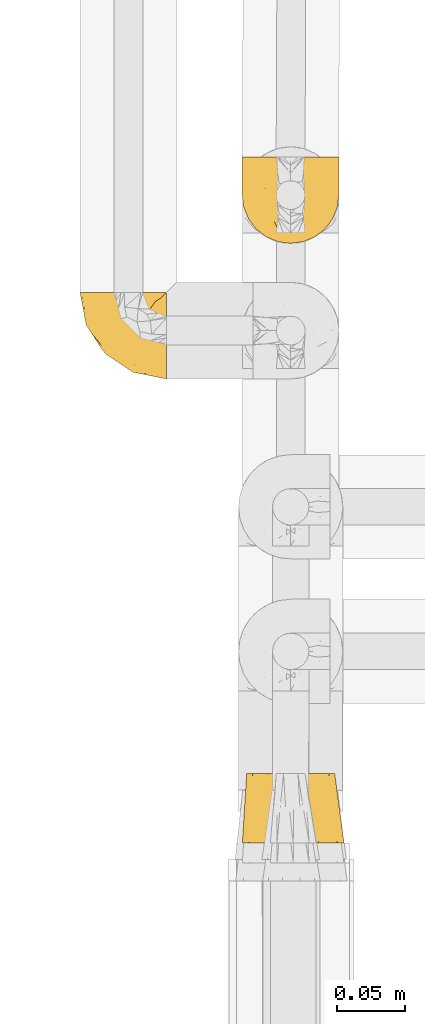
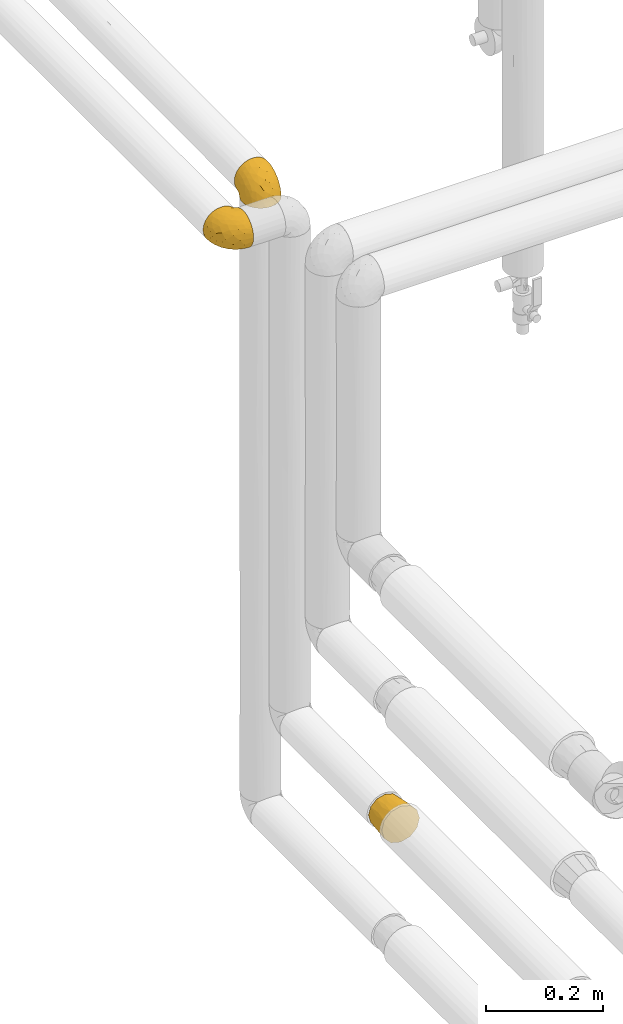
# One storey, part 80 of 827: 3 coverings.
"""IFC2X3 building model written with IfcOpenShell, lengths in millimetres."""

from ifc_helpers import new_model, entity, si_unit, converted_unit, derived_unit, direction, frame, origin, place, context, subcontext, project, spatial, faceted_brep, element, save


model = new_model("IFC2X3")

# Units and contexts
model_context = context("Model", 3, precision=0.01, world=origin(), true_north=direction((6.12303176911189e-17, 1.0)))
body_context = subcontext(model_context, "Body", "Model", "MODEL_VIEW")
ifc_project = project(units=[si_unit("LENGTHUNIT", "METRE", prefix="MILLI"), si_unit("AREAUNIT", "SQUARE_METRE"), si_unit("VOLUMEUNIT", "CUBIC_METRE"), converted_unit("PLANEANGLEUNIT", "DEGREE", entity("IfcRatioMeasure", 0.0174532925199433), si_unit("PLANEANGLEUNIT", "RADIAN"), dimensions=[0, 0, 0, 0, 0, 0, 0]), si_unit("MASSUNIT", "GRAM", prefix="KILO"), derived_unit("MASSDENSITYUNIT", [(si_unit("MASSUNIT", "GRAM", prefix="KILO"), 1), (si_unit("LENGTHUNIT", "METRE"), -3)]), derived_unit("MOMENTOFINERTIAUNIT", [(si_unit("LENGTHUNIT", "METRE"), 4)]), si_unit("TIMEUNIT", "SECOND"), si_unit("FREQUENCYUNIT", "HERTZ"), si_unit("THERMODYNAMICTEMPERATUREUNIT", "DEGREE_CELSIUS"), derived_unit("THERMALTRANSMITTANCEUNIT", [(si_unit("MASSUNIT", "GRAM", prefix="KILO"), 1), (si_unit("THERMODYNAMICTEMPERATUREUNIT", "KELVIN"), -1), (si_unit("TIMEUNIT", "SECOND"), -3)]), derived_unit("VOLUMETRICFLOWRATEUNIT", [(si_unit("LENGTHUNIT", "METRE"), 3), (si_unit("TIMEUNIT", "SECOND"), -1)]), derived_unit("MASSFLOWRATEUNIT", [(si_unit("MASSUNIT", "GRAM", prefix="KILO"), 1), (si_unit("TIMEUNIT", "SECOND"), -1)]), derived_unit("ROTATIONALFREQUENCYUNIT", [(si_unit("TIMEUNIT", "SECOND"), -1)]), si_unit("ELECTRICCURRENTUNIT", "AMPERE"), si_unit("ELECTRICVOLTAGEUNIT", "VOLT"), si_unit("POWERUNIT", "WATT"), si_unit("FORCEUNIT", "NEWTON", prefix="KILO"), si_unit("ILLUMINANCEUNIT", "LUX"), si_unit("LUMINOUSFLUXUNIT", "LUMEN"), si_unit("LUMINOUSINTENSITYUNIT", "CANDELA"), derived_unit("USERDEFINED", [(si_unit("MASSUNIT", "GRAM", prefix="KILO"), -1), (si_unit("LENGTHUNIT", "METRE"), -2), (si_unit("TIMEUNIT", "SECOND"), 3), (si_unit("LUMINOUSFLUXUNIT", "LUMEN"), 1)]), derived_unit("LINEARVELOCITYUNIT", [(si_unit("LENGTHUNIT", "METRE"), 1), (si_unit("TIMEUNIT", "SECOND"), -1)]), si_unit("PRESSUREUNIT", "PASCAL"), derived_unit("USERDEFINED", [(si_unit("LENGTHUNIT", "METRE"), -2), (si_unit("MASSUNIT", "GRAM", prefix="KILO"), 1), (si_unit("TIMEUNIT", "SECOND"), -2)]), derived_unit("LINEARFORCEUNIT", [(si_unit("MASSUNIT", "GRAM", prefix="KILO"), 1), (si_unit("LENGTHUNIT", "METRE"), 1), (si_unit("TIMEUNIT", "SECOND"), -2), (si_unit("LENGTHUNIT", "METRE"), -1)]), derived_unit("PLANARFORCEUNIT", [(si_unit("MASSUNIT", "GRAM", prefix="KILO"), 1), (si_unit("LENGTHUNIT", "METRE"), 1), (si_unit("TIMEUNIT", "SECOND"), -2), (si_unit("LENGTHUNIT", "METRE"), -2)])], contexts=[model_context])

# Site, building, storey
site_placement = place(None, origin())
site = spatial("IfcSite", under=ifc_project, at=site_placement, CompositionType="ELEMENT")
building_placement = place(site_placement, origin())
building = spatial("IfcBuilding", under=site, at=building_placement, CompositionType="ELEMENT")
storey_placement = place(building_placement, frame((0.0, 0.0, 28200.0)))
storey = spatial("IfcBuildingStorey", under=building, at=storey_placement, Name="08", CompositionType="ELEMENT", Elevation=28200.0)

# Coverings
covering_1_placement = place(storey_placement, frame((17769.65, 11958.96, 1862.75)))
element("IfcCovering", 1, at=covering_1_placement, inside=storey, Name=":ADSK_", ObjectType=":ADSK_", PredefinedType="INSULATION", context=body_context, shape_type="Brep", body=[
    faceted_brep([(65.25, 21.77, 69.36), (65.25, 15.01, 65.11), (65.25, 9.37, 59.47), (65.25, 5.12, 52.71), (65.25, 2.49, 45.17), (65.25, 1.6, 37.25), (65.25, 2.49, 29.31), (65.25, 5.13, 21.77), (65.25, 9.38, 15.01), (65.25, 15.02, 9.37), (65.25, 21.78, 5.12), (65.25, 29.32, 2.49), (65.25, 37.25, 1.6), (65.25, 45.15, 2.48), (65.25, 52.65, 5.1), (65.25, 59.39, 9.31), (65.25, 65.02, 14.9), (65.25, 65.02, 16.96), (65.25, 65.02, 18.43), (65.25, 65.02, 20.19), (65.25, 65.02, 21.96), (65.25, 65.02, 23.72), (65.25, 65.02, 25.49), (65.25, 65.02, 27.25), (65.25, 65.02, 29.02), (65.25, 65.02, 30.78), (65.25, 65.02, 32.55), (65.25, 65.02, 34.31), (65.25, 65.02, 36.08), (65.25, 65.02, 37.84), (65.25, 65.02, 39.61), (65.25, 65.02, 41.37), (65.25, 65.02, 43.14), (65.25, 65.02, 45.19), (65.25, 65.02, 47.25), (65.25, 65.02, 49.31), (65.25, 65.02, 51.36), (65.25, 65.02, 53.42), (65.25, 65.02, 55.48), (65.25, 65.02, 57.53), (65.25, 65.02, 59.59), (65.25, 59.38, 65.19), (65.25, 52.64, 69.4), (65.25, 45.13, 72.01), (65.25, 37.25, 72.9), (65.25, 29.31, 72.0), (65.02, 65.25, 14.9), (59.38, 65.25, 9.3), (52.65, 65.25, 5.09), (45.14, 65.25, 2.48), (37.25, 65.25, 1.6), (28.02, 65.25, 2.81), (19.42, 65.25, 6.37), (12.04, 65.25, 12.04), (6.37, 65.25, 19.42), (2.81, 65.25, 28.02), (1.6, 65.25, 37.25), (2.81, 65.25, 46.47), (6.37, 65.25, 55.07), (12.04, 65.25, 62.45), (19.42, 65.25, 68.12), (28.02, 65.25, 71.68), (37.25, 65.25, 72.9), (45.14, 65.25, 72.01), (52.65, 65.25, 69.4), (59.38, 65.25, 65.19), (65.02, 65.25, 59.59), (65.02, 65.25, 58.56), (65.02, 65.25, 56.8), (65.02, 65.25, 55.4), (65.02, 65.25, 54.0), (65.02, 65.25, 52.61), (65.02, 65.25, 51.21), (65.02, 65.25, 49.81), (65.02, 65.25, 48.42), (65.02, 65.25, 47.02), (65.02, 65.25, 45.62), (65.02, 65.25, 44.23), (65.02, 65.25, 42.83), (65.02, 65.25, 41.43), (65.02, 65.25, 40.04), (65.02, 65.25, 38.64), (65.02, 65.25, 37.25), (65.02, 65.25, 35.48), (65.02, 65.25, 33.72), (65.02, 65.25, 31.95), (65.02, 65.25, 30.19), (65.02, 65.25, 28.42), (65.02, 65.25, 26.66), (65.02, 65.25, 24.89), (65.02, 65.25, 23.13), (65.02, 65.25, 21.07), (65.02, 65.25, 19.01), (65.02, 65.25, 16.96), (65.09, 65.08, 50.36), (65.08, 65.09, 51.91), (65.08, 65.09, 27.73), (65.08, 65.1, 29.06), (65.1, 65.08, 23.0), (65.08, 65.09, 39.29), (65.09, 65.09, 16.3), (65.09, 65.09, 17.69), (65.09, 65.09, 42.09), (65.08, 65.1, 43.53), (65.1, 65.08, 58.23), (65.09, 65.09, 59.59), (65.1, 65.08, 46.32), (65.08, 65.09, 47.68), (65.09, 65.08, 19.0), (65.09, 65.09, 30.39), (65.1, 65.07, 31.67), (65.08, 65.1, 37.94), (65.08, 65.09, 36.57), (65.08, 65.1, 45.01), (65.11, 65.07, 35.19), (65.1, 65.07, 26.37), (65.09, 65.09, 25.1), (65.1, 65.08, 56.91), (65.09, 65.09, 40.68), (65.06, 65.13, 32.77), (65.08, 65.1, 20.34), (65.08, 65.09, 21.67), (65.09, 65.09, 33.92), (65.08, 65.1, 53.39), (65.09, 65.09, 54.7), (65.09, 65.09, 14.9), (65.08, 65.09, 49.03), (53.73, 53.74, 3.58), (58.66, 57.19, 6.24), (41.0, 51.25, 1.6), (38.71, 59.77, 1.6), (51.25, 41.0, 1.6), (61.64, 61.64, 9.92), (46.12, 46.12, 1.6), (59.77, 38.71, 1.6), (31.28, 13.0, 27.59), (49.86, 5.55, 25.47), (40.89, 6.44, 37.25), (31.44, 55.39, 2.33), (34.1, 48.48, 2.37), (23.33, 39.63, 8.53), (13.33, 43.5, 15.54), (17.24, 52.38, 8.96), (26.77, 49.31, 4.31), (24.24, 58.01, 4.31), (46.39, 22.23, 7.06), (56.32, 19.14, 7.06), (51.97, 13.73, 12.03), (41.92, 39.1, 2.3), (32.23, 15.38, 21.13), (5.01, 46.7, 30.63), (6.41, 49.4, 23.6), (52.55, 4.12, 37.25), (9.84, 55.35, 15.54), (24.05, 23.83, 18.65), (33.5, 19.0, 15.3), (45.31, 32.44, 3.14), (55.32, 26.73, 3.59), (54.18, 8.12, 18.27), (32.73, 31.34, 7.07), (34.55, 38.81, 3.86), (42.44, 16.11, 13.04), (41.89, 11.96, 18.27), (22.65, 20.31, 26.27), (10.6, 38.81, 23.06), (10.01, 35.48, 29.25), (15.9, 28.94, 24.41), (16.46, 25.21, 31.04), (20.24, 20.24, 37.25), (30.56, 13.34, 37.25), (4.12, 52.55, 37.25), (19.45, 33.16, 15.08), (27.92, 27.33, 12.03), (37.29, 22.86, 9.82), (40.02, 27.48, 6.14), (6.44, 40.89, 37.25), (13.34, 30.56, 37.25), (25.04, 54.41, 70.18), (5.04, 46.71, 44.04), (17.52, 26.31, 49.17), (31.3, 12.98, 46.9), (51.97, 13.72, 62.45), (54.19, 8.12, 56.21), (19.41, 46.04, 65.53), (10.78, 51.06, 58.95), (16.67, 35.69, 58.17), (46.4, 22.22, 67.43), (56.32, 19.13, 67.43), (55.32, 26.72, 70.89), (28.05, 19.65, 55.13), (32.97, 51.87, 72.21), (41.0, 51.25, 72.9), (39.12, 58.25, 72.9), (59.77, 38.71, 72.9), (4.71, 54.36, 49.42), (16.32, 56.5, 65.53), (10.37, 34.9, 45.41), (8.45, 43.16, 50.89), (49.86, 5.54, 49.01), (27.54, 35.66, 66.8), (28.28, 47.21, 70.39), (41.9, 11.95, 56.21), (36.5, 46.27, 72.31), (40.35, 39.95, 72.1), (51.25, 41.0, 72.9), (46.12, 46.12, 72.9), (40.24, 18.27, 62.45), (45.3, 32.43, 71.35), (31.14, 58.69, 72.26), (27.93, 27.31, 62.45), (36.19, 29.52, 67.99), (21.94, 35.02, 62.85), (32.75, 40.81, 70.57), (53.73, 53.74, 70.91), (57.19, 58.66, 68.25), (61.64, 61.64, 64.57)], [[[0, 1, 2, 3, 4, 5, 6, 7, 8, 9, 10, 11, 12, 13, 14, 15, 16, 17, 18, 19, 20, 21, 22, 23, 24, 25, 26, 27, 28, 29, 30, 31, 32, 33, 34, 35, 36, 37, 38, 39, 40, 41, 42, 43, 44, 45]], [[46, 47, 48, 49, 50, 51, 52, 53, 54, 55, 56, 57, 58, 59, 60, 61, 62, 63, 64, 65, 66, 67, 68, 69, 70, 71, 72, 73, 74, 75, 76, 77, 78, 79, 80, 81, 82, 83, 84, 85, 86, 87, 88, 89, 90, 91, 92, 93]], [[94, 72, 95]], [[96, 87, 97]], [[20, 98, 21]], [[99, 81, 80]], [[100, 93, 101]], [[102, 103, 32]], [[104, 105, 40]], [[67, 105, 104]], [[106, 107, 34]], [[18, 101, 108]], [[109, 85, 110]], [[36, 94, 95]], [[81, 111, 82]], [[29, 28, 112]], [[17, 101, 18]], [[103, 113, 33]], [[24, 96, 97]], [[28, 114, 112]], [[115, 22, 116]], [[31, 102, 32]], [[68, 104, 117]], [[31, 118, 102]], [[84, 119, 85]], [[120, 91, 121]], [[23, 22, 115]], [[114, 27, 122]], [[123, 37, 95]], [[117, 124, 69]], [[67, 66, 105]], [[104, 39, 117]], [[123, 124, 37]], [[100, 17, 16]], [[100, 125, 46]], [[17, 100, 101]], [[107, 126, 35]], [[92, 108, 101]], [[115, 88, 96]], [[114, 122, 83]], [[101, 93, 92]], [[93, 100, 46]], [[16, 125, 100]], [[108, 19, 18]], [[120, 121, 19]], [[108, 92, 120]], [[19, 108, 120]], [[67, 104, 68]], [[39, 104, 40]], [[69, 68, 117]], [[117, 39, 38]], [[70, 124, 123]], [[124, 70, 69]], [[38, 124, 117]], [[124, 38, 37]], [[72, 71, 95]], [[71, 123, 95]], [[71, 70, 123]], [[126, 94, 35]], [[37, 36, 95]], [[75, 74, 107]], [[73, 72, 94]], [[94, 36, 35]], [[94, 126, 73]], [[74, 73, 126]], [[106, 76, 75]], [[76, 106, 113]], [[113, 106, 33]], [[107, 35, 34]], [[106, 34, 33]], [[126, 107, 74]], [[107, 106, 75]], [[78, 77, 103]], [[77, 113, 103]], [[77, 76, 113]], [[102, 78, 103]], [[33, 32, 103]], [[80, 79, 118]], [[102, 118, 79]], [[112, 111, 29]], [[118, 31, 30]], [[79, 78, 102]], [[99, 111, 81]], [[112, 82, 111]], [[111, 99, 29]], [[30, 29, 99]], [[112, 83, 82]], [[27, 114, 28]], [[99, 118, 30]], [[118, 99, 80]], [[114, 83, 112]], [[84, 83, 122]], [[109, 110, 25]], [[122, 27, 26]], [[119, 110, 85]], [[20, 19, 121]], [[25, 110, 26]], [[91, 120, 92]], [[90, 98, 121]], [[121, 91, 90]], [[23, 115, 96]], [[88, 115, 116]], [[116, 98, 89]], [[89, 88, 116]], [[23, 96, 24]], [[87, 96, 88]], [[25, 24, 109]], [[97, 87, 86]], [[90, 89, 98]], [[116, 22, 21]], [[122, 26, 119]], [[86, 85, 109]], [[109, 97, 86]], [[97, 109, 24]], [[110, 119, 26]], [[122, 119, 84]], [[121, 98, 20]], [[21, 98, 116]], [[48, 127, 49]], [[48, 47, 128]], [[49, 129, 130, 50]], [[129, 49, 127]], [[131, 127, 13]], [[46, 125, 132]], [[16, 15, 132]], [[127, 128, 14]], [[127, 131, 133, 129]], [[14, 13, 127]], [[13, 12, 134, 131]], [[46, 132, 47]], [[48, 128, 127]], [[47, 132, 128]], [[15, 128, 132]], [[125, 16, 132]], [[15, 14, 128]], [[135, 136, 137]], [[138, 129, 139]], [[140, 141, 142]], [[143, 144, 138]], [[145, 146, 147]], [[133, 148, 139]], [[134, 12, 11]], [[136, 135, 149]], [[150, 55, 151]], [[136, 6, 152]], [[153, 54, 53]], [[52, 144, 142]], [[52, 142, 53]], [[54, 153, 151]], [[144, 52, 51]], [[154, 155, 149]], [[156, 131, 157]], [[134, 11, 157]], [[8, 7, 158]], [[147, 9, 8]], [[157, 131, 134]], [[157, 11, 10]], [[146, 157, 10]], [[159, 140, 160]], [[157, 145, 156]], [[161, 162, 155]], [[161, 147, 162]], [[154, 149, 163]], [[150, 164, 165]], [[136, 7, 6]], [[137, 136, 152]], [[162, 158, 136]], [[54, 151, 55]], [[158, 147, 8]], [[166, 167, 165]], [[9, 146, 10]], [[164, 166, 165]], [[168, 135, 137, 169]], [[55, 150, 170]], [[154, 171, 172]], [[139, 148, 160]], [[140, 142, 143]], [[153, 142, 141]], [[51, 50, 130]], [[145, 173, 174]], [[156, 160, 148]], [[6, 5, 152]], [[136, 158, 7]], [[147, 158, 162]], [[147, 146, 9]], [[157, 146, 145]], [[160, 140, 143]], [[140, 172, 171]], [[139, 143, 138]], [[173, 159, 174]], [[170, 150, 175]], [[170, 56, 55]], [[167, 168, 176]], [[176, 175, 165]], [[150, 165, 175]], [[163, 167, 166]], [[176, 165, 167]], [[164, 150, 151]], [[151, 141, 164]], [[171, 164, 141]], [[154, 163, 166]], [[163, 135, 168]], [[166, 164, 171]], [[155, 154, 172]], [[166, 171, 154]], [[140, 171, 141]], [[173, 155, 172]], [[149, 155, 162]], [[159, 173, 172]], [[161, 145, 147]], [[140, 159, 172]], [[174, 160, 156]], [[136, 149, 162]], [[149, 135, 163]], [[155, 173, 161]], [[145, 161, 173]], [[160, 174, 159]], [[156, 148, 131]], [[156, 145, 174]], [[142, 153, 53]], [[151, 153, 141]], [[138, 51, 130]], [[142, 144, 143]], [[51, 138, 144]], [[129, 138, 130]], [[133, 139, 129]], [[160, 143, 139]], [[168, 167, 163]], [[131, 148, 133]], [[60, 177, 61]], [[175, 178, 170]], [[179, 168, 180]], [[178, 57, 170]], [[181, 182, 2]], [[183, 184, 185]], [[186, 187, 188]], [[189, 185, 179]], [[190, 191, 192]], [[45, 193, 188]], [[194, 184, 58]], [[45, 44, 193]], [[59, 195, 60]], [[60, 195, 177]], [[0, 45, 188]], [[196, 179, 197]], [[180, 137, 198]], [[183, 199, 200]], [[201, 182, 181]], [[1, 181, 2]], [[57, 178, 194]], [[198, 3, 182]], [[198, 152, 4]], [[1, 0, 187]], [[190, 202, 191]], [[203, 204, 205]], [[206, 201, 181]], [[186, 188, 207]], [[188, 204, 207]], [[3, 198, 4]], [[58, 184, 59]], [[187, 181, 1]], [[180, 198, 201]], [[206, 181, 186]], [[180, 189, 179]], [[3, 2, 182]], [[180, 168, 169, 137]], [[204, 188, 193]], [[177, 190, 208]], [[209, 210, 199]], [[210, 186, 207]], [[185, 184, 197]], [[195, 184, 183]], [[205, 202, 203]], [[210, 209, 206]], [[179, 185, 197]], [[211, 209, 199]], [[196, 197, 178]], [[180, 201, 189]], [[152, 198, 137]], [[152, 5, 4]], [[61, 208, 62]], [[198, 182, 201]], [[188, 187, 0]], [[181, 187, 186]], [[203, 210, 207]], [[202, 205, 191]], [[199, 210, 212]], [[57, 56, 170]], [[176, 196, 175]], [[178, 197, 194]], [[179, 176, 168]], [[175, 196, 178]], [[176, 179, 196]], [[184, 194, 197]], [[58, 57, 194]], [[208, 190, 192]], [[200, 190, 177]], [[206, 189, 201]], [[185, 189, 209]], [[62, 208, 192]], [[177, 208, 61]], [[210, 206, 186]], [[189, 206, 209]], [[200, 199, 212]], [[211, 183, 185]], [[184, 195, 59]], [[177, 195, 183]], [[183, 200, 177]], [[202, 200, 212]], [[200, 202, 190]], [[202, 212, 203]], [[210, 203, 212]], [[204, 203, 207]], [[183, 211, 199]], [[185, 209, 211]], [[63, 62, 192, 191]], [[64, 63, 213]], [[64, 213, 214]], [[65, 215, 66]], [[213, 191, 205, 204]], [[43, 204, 193, 44]], [[65, 214, 215]], [[42, 213, 43]], [[215, 105, 66]], [[41, 214, 42]], [[40, 105, 215]], [[65, 64, 214]], [[40, 215, 41]], [[213, 63, 191]], [[42, 214, 213]], [[204, 43, 213]], [[214, 41, 215]]]),
])
covering_2_placement = place(storey_placement, frame((17889.43, 11618.2, 806.65)))
element("IfcCovering", 2, at=covering_2_placement, inside=storey, Name=":ADSK_", ObjectType=":ADSK_", PredefinedType="INSULATION", context=body_context, shape_type="Brep", body=[
    faceted_brep([(67.62, 51.0, 47.22), (69.79, 51.0, 39.1), (67.62, 51.0, 30.97), (65.44, 51.0, 22.85), (59.49, 51.0, 16.9), (53.54, 51.0, 10.95), (45.42, 51.0, 8.77), (37.29, 51.0, 6.6), (29.17, 51.0, 8.77), (21.04, 51.0, 10.95), (15.1, 51.0, 16.9), (9.15, 51.0, 22.85), (6.97, 51.0, 30.97), (4.79, 51.0, 39.1), (6.97, 51.0, 47.22), (9.15, 51.0, 55.35), (15.1, 51.0, 61.29), (21.04, 51.0, 67.24), (29.17, 51.0, 69.42), (37.29, 51.0, 71.6), (45.42, 51.0, 69.42), (53.54, 51.0, 67.24), (59.49, 51.0, 61.29), (65.44, 51.0, 55.35), (20.35, 0.0, 71.57), (13.48, 0.0, 64.71), (6.62, 0.0, 57.85), (3.52, 0.0, 46.29), (1.6, 0.0, 39.1), (4.11, 0.0, 29.72), (6.62, 0.0, 20.35), (13.48, 0.0, 13.48), (20.35, 0.0, 6.62), (31.9, 0.0, 3.52), (39.1, 0.0, 1.6), (48.47, 0.0, 4.11), (57.85, 0.0, 6.62), (64.71, 0.0, 13.48), (71.57, 0.0, 20.35), (74.67, 0.0, 31.91), (76.6, 0.0, 39.1), (74.08, 0.0, 48.47), (71.57, 0.0, 57.85), (64.71, 0.0, 64.71), (57.85, 0.0, 71.57), (46.28, 0.0, 74.67), (39.1, 0.0, 76.6), (29.72, 0.0, 74.08), (70.53, 25.5, 25.7), (72.37, 26.64, 32.29), (67.05, 25.5, 19.28), (46.89, 25.5, 5.19), (59.5, 25.5, 11.33), (53.27, 25.5, 7.51), (73.08, 26.37, 39.1), (38.16, 26.37, 4.18), (24.8, 25.5, 6.76), (31.34, 26.64, 4.88), (18.38, 25.5, 10.24), (4.29, 25.5, 30.4), (10.43, 25.5, 17.79), (6.61, 25.5, 24.02), (3.25, 26.44, 39.1), (5.86, 25.5, 52.49), (3.94, 26.64, 45.9), (9.34, 25.5, 58.91), (29.5, 25.5, 73.0), (16.89, 25.5, 66.86), (23.12, 25.5, 70.68), (38.16, 26.44, 74.0), (51.59, 25.5, 71.43), (44.96, 26.64, 73.31), (58.01, 25.5, 67.95), (72.1, 25.5, 47.79), (65.96, 25.5, 60.4), (69.78, 25.5, 54.17)], [[[0, 1, 2, 3, 4, 5, 6, 7, 8, 9, 10, 11, 12, 13, 14, 15, 16, 17, 18, 19, 20, 21, 22, 23]], [[24, 25, 26, 27, 28, 29, 30, 31, 32, 33, 34, 35, 36, 37, 38, 39, 40, 41, 42, 43, 44, 45, 46, 47]], [[39, 48, 49]], [[49, 40, 39]], [[48, 39, 38]], [[3, 2, 48]], [[50, 3, 48]], [[48, 2, 49]], [[7, 6, 51]], [[52, 50, 37]], [[50, 48, 38]], [[5, 52, 53]], [[53, 52, 36]], [[37, 36, 52]], [[50, 38, 37]], [[54, 40, 49, 1]], [[52, 4, 50]], [[4, 3, 50]], [[4, 52, 5]], [[51, 6, 53]], [[53, 35, 51]], [[53, 36, 35]], [[1, 49, 2]], [[6, 5, 53]], [[34, 55, 7, 51]], [[34, 51, 35]], [[33, 56, 57]], [[57, 34, 33]], [[56, 33, 32]], [[9, 8, 56]], [[58, 9, 56]], [[56, 8, 57]], [[13, 12, 59]], [[60, 58, 31]], [[58, 56, 32]], [[11, 60, 61]], [[61, 60, 30]], [[31, 30, 60]], [[58, 32, 31]], [[55, 34, 57, 7]], [[60, 10, 58]], [[10, 9, 58]], [[10, 60, 11]], [[59, 12, 61]], [[61, 29, 59]], [[61, 30, 29]], [[7, 57, 8]], [[12, 11, 61]], [[28, 62, 13, 59]], [[28, 59, 29]], [[27, 63, 64]], [[64, 28, 27]], [[63, 27, 26]], [[15, 14, 63]], [[65, 15, 63]], [[63, 14, 64]], [[19, 18, 66]], [[67, 65, 25]], [[65, 63, 26]], [[17, 67, 68]], [[68, 67, 24]], [[25, 24, 67]], [[65, 26, 25]], [[62, 28, 64, 13]], [[67, 16, 65]], [[16, 15, 65]], [[16, 67, 17]], [[66, 18, 68]], [[68, 47, 66]], [[68, 24, 47]], [[13, 64, 14]], [[18, 17, 68]], [[46, 69, 19, 66]], [[46, 66, 47]], [[45, 70, 71]], [[71, 46, 45]], [[70, 45, 44]], [[21, 20, 70]], [[72, 21, 70]], [[70, 20, 71]], [[1, 0, 73]], [[74, 72, 43]], [[72, 70, 44]], [[23, 74, 75]], [[75, 74, 42]], [[43, 42, 74]], [[72, 44, 43]], [[69, 46, 71, 19]], [[74, 22, 72]], [[22, 21, 72]], [[22, 74, 23]], [[73, 0, 75]], [[75, 41, 73]], [[75, 42, 41]], [[19, 71, 20]], [[0, 23, 75]], [[40, 54, 1, 73]], [[40, 73, 41]]]),
])
covering_3_placement = place(storey_placement, frame((17889.35, 12058.96, 1870.4)))
element("IfcCovering", 3, at=covering_3_placement, inside=storey, Name=":ADSK_", ObjectType=":ADSK_", PredefinedType="INSULATION", context=body_context, shape_type="Brep", body=[
    faceted_brep([(5.13, 65.25, 45.07), (9.38, 65.25, 51.83), (15.02, 65.25, 57.47), (21.78, 65.25, 61.72), (29.32, 65.25, 64.35), (37.25, 65.25, 65.25), (45.18, 65.25, 64.35), (52.72, 65.25, 61.71), (59.48, 65.25, 57.46), (65.12, 65.25, 51.82), (69.37, 65.25, 45.06), (72.0, 65.25, 37.52), (72.9, 65.25, 29.6), (72.01, 65.25, 21.69), (69.39, 65.25, 14.19), (65.18, 65.25, 7.45), (59.59, 65.25, 1.82), (57.53, 65.25, 1.82), (56.06, 65.25, 1.82), (54.3, 65.25, 1.82), (52.53, 65.25, 1.82), (50.77, 65.25, 1.82), (49.0, 65.25, 1.82), (47.24, 65.25, 1.82), (45.47, 65.25, 1.82), (43.71, 65.25, 1.82), (41.94, 65.25, 1.82), (40.18, 65.25, 1.82), (38.41, 65.25, 1.82), (36.65, 65.25, 1.82), (34.88, 65.25, 1.82), (33.12, 65.25, 1.82), (31.35, 65.25, 1.82), (29.3, 65.25, 1.82), (27.24, 65.25, 1.82), (25.18, 65.25, 1.82), (23.13, 65.25, 1.82), (21.07, 65.25, 1.82), (19.01, 65.25, 1.82), (16.96, 65.25, 1.82), (14.9, 65.25, 1.82), (9.3, 65.25, 7.46), (5.09, 65.25, 14.2), (2.48, 65.25, 21.71), (1.6, 65.25, 29.6), (2.49, 65.25, 37.53), (59.59, 65.02, 1.6), (65.19, 59.38, 1.6), (69.4, 52.65, 1.6), (72.01, 45.14, 1.6), (72.9, 37.25, 1.6), (71.68, 28.02, 1.6), (68.12, 19.42, 1.6), (62.45, 12.04, 1.6), (55.07, 6.37, 1.6), (46.47, 2.81, 1.6), (37.25, 1.6, 1.6), (28.02, 2.81, 1.6), (19.42, 6.37, 1.6), (12.04, 12.04, 1.6), (6.37, 19.42, 1.6), (2.81, 28.02, 1.6), (1.6, 37.25, 1.6), (2.48, 45.14, 1.6), (5.09, 52.65, 1.6), (9.3, 59.38, 1.6), (14.9, 65.02, 1.6), (15.93, 65.02, 1.6), (17.69, 65.02, 1.6), (19.09, 65.02, 1.6), (20.49, 65.02, 1.6), (21.88, 65.02, 1.6), (23.28, 65.02, 1.6), (24.68, 65.02, 1.6), (26.07, 65.02, 1.6), (27.47, 65.02, 1.6), (28.87, 65.02, 1.6), (30.26, 65.02, 1.6), (31.66, 65.02, 1.6), (33.06, 65.02, 1.6), (34.45, 65.02, 1.6), (35.85, 65.02, 1.6), (37.25, 65.02, 1.6), (39.01, 65.02, 1.6), (40.77, 65.02, 1.6), (42.54, 65.02, 1.6), (44.3, 65.02, 1.6), (46.07, 65.02, 1.6), (47.83, 65.02, 1.6), (49.6, 65.02, 1.6), (51.36, 65.02, 1.6), (53.42, 65.02, 1.6), (55.48, 65.02, 1.6), (57.53, 65.02, 1.6), (24.13, 65.09, 1.76), (22.58, 65.08, 1.75), (46.76, 65.08, 1.75), (45.43, 65.08, 1.74), (51.49, 65.1, 1.76), (35.2, 65.08, 1.75), (58.19, 65.09, 1.75), (56.8, 65.09, 1.75), (32.4, 65.09, 1.75), (30.96, 65.08, 1.75), (16.26, 65.1, 1.76), (14.9, 65.09, 1.75), (28.17, 65.1, 1.76), (26.81, 65.08, 1.75), (55.49, 65.09, 1.76), (44.1, 65.09, 1.75), (42.83, 65.1, 1.77), (36.55, 65.08, 1.74), (37.92, 65.08, 1.75), (29.48, 65.08, 1.75), (39.3, 65.11, 1.77), (48.12, 65.1, 1.77), (49.39, 65.09, 1.75), (17.58, 65.1, 1.76), (33.81, 65.09, 1.75), (41.72, 65.06, 1.71), (54.15, 65.08, 1.74), (52.82, 65.08, 1.75), (40.57, 65.09, 1.75), (21.1, 65.08, 1.74), (19.79, 65.09, 1.75), (59.59, 65.09, 1.75), (25.46, 65.08, 1.75), (70.91, 53.73, 13.1), (68.25, 58.66, 9.65), (72.9, 41.0, 15.6), (72.9, 38.71, 7.07), (72.9, 51.25, 25.84), (64.57, 61.64, 5.2), (72.9, 46.12, 20.72), (72.9, 59.77, 28.13), (46.9, 31.28, 53.84), (49.02, 49.86, 61.29), (37.25, 40.89, 60.4), (72.16, 31.44, 11.45), (72.12, 34.1, 18.37), (65.96, 23.33, 27.21), (58.95, 13.33, 23.34), (65.53, 17.24, 14.46), (70.18, 26.77, 17.53), (70.18, 24.24, 8.83), (67.43, 46.39, 44.61), (67.43, 56.32, 47.7), (62.46, 51.97, 53.12), (72.19, 41.92, 27.74), (53.36, 32.23, 51.46), (43.86, 5.01, 20.14), (50.89, 6.41, 17.44), (37.25, 52.55, 62.72), (58.95, 9.84, 11.49), (55.84, 24.05, 43.01), (59.19, 33.5, 47.84), (71.35, 45.31, 34.4), (70.9, 55.32, 40.11), (56.22, 54.18, 58.72), (67.42, 32.73, 35.5), (70.63, 34.55, 28.03), (61.45, 42.44, 50.73), (56.22, 41.89, 54.88), (48.22, 22.65, 46.53), (51.43, 10.6, 28.03), (45.24, 10.01, 31.36), (50.08, 15.9, 37.9), (43.45, 16.46, 41.63), (37.25, 20.24, 46.6), (37.25, 30.56, 53.5), (37.25, 4.12, 14.29), (59.41, 19.45, 33.68), (62.46, 27.92, 39.51), (64.67, 37.29, 43.98), (68.35, 40.02, 39.36), (37.25, 6.44, 25.95), (37.25, 13.34, 36.28), (4.31, 25.04, 12.43), (30.45, 5.04, 20.13), (25.32, 17.52, 40.53), (27.59, 31.3, 53.86), (12.04, 51.97, 53.13), (18.28, 54.19, 58.72), (8.96, 19.41, 20.81), (15.54, 10.78, 15.78), (16.32, 16.67, 31.15), (7.06, 46.4, 44.62), (7.06, 56.32, 47.71), (3.6, 55.32, 40.12), (19.36, 28.05, 47.19), (2.28, 32.97, 14.97), (1.6, 41.0, 15.6), (1.6, 39.12, 8.6), (1.6, 59.77, 28.13), (25.07, 4.71, 12.48), (8.96, 16.32, 10.34), (29.08, 10.37, 31.94), (23.6, 8.45, 23.68), (25.48, 49.86, 61.3), (7.69, 27.54, 31.18), (4.1, 28.28, 19.63), (18.28, 41.9, 54.89), (2.18, 36.5, 20.57), (2.39, 40.35, 26.89), (1.6, 51.25, 25.84), (1.6, 46.12, 20.72), (12.04, 40.24, 48.57), (3.15, 45.3, 34.41), (2.24, 31.14, 8.15), (12.04, 27.93, 39.53), (6.5, 36.19, 37.32), (11.64, 21.94, 31.82), (3.92, 32.75, 26.03), (3.58, 53.73, 13.1), (6.24, 57.19, 8.18), (9.92, 61.64, 5.2)], [[[0, 1, 2, 3, 4, 5, 6, 7, 8, 9, 10, 11, 12, 13, 14, 15, 16, 17, 18, 19, 20, 21, 22, 23, 24, 25, 26, 27, 28, 29, 30, 31, 32, 33, 34, 35, 36, 37, 38, 39, 40, 41, 42, 43, 44, 45]], [[46, 47, 48, 49, 50, 51, 52, 53, 54, 55, 56, 57, 58, 59, 60, 61, 62, 63, 64, 65, 66, 67, 68, 69, 70, 71, 72, 73, 74, 75, 76, 77, 78, 79, 80, 81, 82, 83, 84, 85, 86, 87, 88, 89, 90, 91, 92, 93]], [[94, 72, 95]], [[96, 87, 97]], [[20, 98, 21]], [[99, 81, 80]], [[100, 93, 101]], [[102, 103, 32]], [[104, 105, 40]], [[67, 105, 104]], [[106, 107, 34]], [[18, 101, 108]], [[109, 85, 110]], [[36, 94, 95]], [[81, 111, 82]], [[29, 28, 112]], [[17, 101, 18]], [[103, 113, 33]], [[24, 96, 97]], [[28, 114, 112]], [[115, 22, 116]], [[31, 102, 32]], [[68, 104, 117]], [[31, 118, 102]], [[84, 119, 85]], [[120, 91, 121]], [[23, 22, 115]], [[114, 27, 122]], [[123, 37, 95]], [[117, 124, 69]], [[67, 66, 105]], [[104, 39, 117]], [[123, 124, 37]], [[100, 17, 16]], [[100, 125, 46]], [[17, 100, 101]], [[107, 126, 35]], [[92, 108, 101]], [[115, 88, 96]], [[114, 122, 83]], [[101, 93, 92]], [[93, 100, 46]], [[16, 125, 100]], [[108, 19, 18]], [[120, 121, 19]], [[108, 92, 120]], [[19, 108, 120]], [[67, 104, 68]], [[39, 104, 40]], [[69, 68, 117]], [[117, 39, 38]], [[70, 124, 123]], [[124, 70, 69]], [[38, 124, 117]], [[124, 38, 37]], [[72, 71, 95]], [[71, 123, 95]], [[71, 70, 123]], [[126, 94, 35]], [[37, 36, 95]], [[75, 74, 107]], [[73, 72, 94]], [[94, 36, 35]], [[94, 126, 73]], [[74, 73, 126]], [[106, 76, 75]], [[76, 106, 113]], [[113, 106, 33]], [[107, 35, 34]], [[106, 34, 33]], [[126, 107, 74]], [[107, 106, 75]], [[78, 77, 103]], [[77, 113, 103]], [[77, 76, 113]], [[102, 78, 103]], [[33, 32, 103]], [[80, 79, 118]], [[102, 118, 79]], [[112, 111, 29]], [[118, 31, 30]], [[79, 78, 102]], [[99, 111, 81]], [[112, 82, 111]], [[111, 99, 29]], [[30, 29, 99]], [[112, 83, 82]], [[27, 114, 28]], [[99, 118, 30]], [[118, 99, 80]], [[114, 83, 112]], [[84, 83, 122]], [[109, 110, 25]], [[122, 27, 26]], [[119, 110, 85]], [[20, 19, 121]], [[25, 110, 26]], [[91, 120, 92]], [[90, 98, 121]], [[121, 91, 90]], [[23, 115, 96]], [[88, 115, 116]], [[116, 98, 89]], [[89, 88, 116]], [[23, 96, 24]], [[87, 96, 88]], [[25, 24, 109]], [[97, 87, 86]], [[90, 89, 98]], [[116, 22, 21]], [[122, 26, 119]], [[86, 85, 109]], [[109, 97, 86]], [[97, 109, 24]], [[110, 119, 26]], [[122, 119, 84]], [[121, 98, 20]], [[21, 98, 116]], [[48, 127, 49]], [[48, 47, 128]], [[49, 129, 130, 50]], [[129, 49, 127]], [[131, 127, 13]], [[46, 125, 132]], [[16, 15, 132]], [[127, 128, 14]], [[127, 131, 133, 129]], [[14, 13, 127]], [[13, 12, 134, 131]], [[46, 132, 47]], [[48, 128, 127]], [[47, 132, 128]], [[15, 128, 132]], [[125, 16, 132]], [[15, 14, 128]], [[135, 136, 137]], [[138, 129, 139]], [[140, 141, 142]], [[143, 144, 138]], [[145, 146, 147]], [[133, 148, 139]], [[134, 12, 11]], [[136, 135, 149]], [[150, 55, 151]], [[136, 6, 152]], [[153, 54, 53]], [[52, 144, 142]], [[52, 142, 53]], [[54, 153, 151]], [[144, 52, 51]], [[154, 155, 149]], [[156, 131, 157]], [[134, 11, 157]], [[8, 7, 158]], [[147, 9, 8]], [[157, 131, 134]], [[157, 11, 10]], [[146, 157, 10]], [[159, 140, 160]], [[157, 145, 156]], [[161, 162, 155]], [[161, 147, 162]], [[154, 149, 163]], [[150, 164, 165]], [[136, 7, 6]], [[137, 136, 152]], [[162, 158, 136]], [[54, 151, 55]], [[158, 147, 8]], [[166, 167, 165]], [[9, 146, 10]], [[164, 166, 165]], [[168, 135, 137, 169]], [[55, 150, 170]], [[154, 171, 172]], [[139, 148, 160]], [[140, 142, 143]], [[153, 142, 141]], [[51, 50, 130]], [[145, 173, 174]], [[156, 160, 148]], [[6, 5, 152]], [[136, 158, 7]], [[147, 158, 162]], [[147, 146, 9]], [[157, 146, 145]], [[160, 140, 143]], [[140, 172, 171]], [[139, 143, 138]], [[173, 159, 174]], [[170, 150, 175]], [[170, 56, 55]], [[167, 168, 176]], [[176, 175, 165]], [[150, 165, 175]], [[163, 167, 166]], [[176, 165, 167]], [[164, 150, 151]], [[151, 141, 164]], [[171, 164, 141]], [[154, 163, 166]], [[163, 135, 168]], [[166, 164, 171]], [[155, 154, 172]], [[166, 171, 154]], [[140, 171, 141]], [[173, 155, 172]], [[149, 155, 162]], [[159, 173, 172]], [[161, 145, 147]], [[140, 159, 172]], [[174, 160, 156]], [[136, 149, 162]], [[149, 135, 163]], [[155, 173, 161]], [[145, 161, 173]], [[160, 174, 159]], [[156, 148, 131]], [[156, 145, 174]], [[142, 153, 53]], [[151, 153, 141]], [[138, 51, 130]], [[142, 144, 143]], [[51, 138, 144]], [[129, 138, 130]], [[133, 139, 129]], [[160, 143, 139]], [[168, 167, 163]], [[131, 148, 133]], [[60, 177, 61]], [[175, 178, 170]], [[179, 168, 180]], [[178, 57, 170]], [[181, 182, 2]], [[183, 184, 185]], [[186, 187, 188]], [[189, 185, 179]], [[190, 191, 192]], [[45, 193, 188]], [[194, 184, 58]], [[45, 44, 193]], [[59, 195, 60]], [[60, 195, 177]], [[0, 45, 188]], [[196, 179, 197]], [[180, 137, 198]], [[183, 199, 200]], [[201, 182, 181]], [[1, 181, 2]], [[57, 178, 194]], [[198, 3, 182]], [[198, 152, 4]], [[1, 0, 187]], [[190, 202, 191]], [[203, 204, 205]], [[206, 201, 181]], [[186, 188, 207]], [[188, 204, 207]], [[3, 198, 4]], [[58, 184, 59]], [[187, 181, 1]], [[180, 198, 201]], [[206, 181, 186]], [[180, 189, 179]], [[3, 2, 182]], [[180, 168, 169, 137]], [[204, 188, 193]], [[177, 190, 208]], [[209, 210, 199]], [[210, 186, 207]], [[185, 184, 197]], [[195, 184, 183]], [[205, 202, 203]], [[210, 209, 206]], [[179, 185, 197]], [[211, 209, 199]], [[196, 197, 178]], [[180, 201, 189]], [[152, 198, 137]], [[152, 5, 4]], [[61, 208, 62]], [[198, 182, 201]], [[188, 187, 0]], [[181, 187, 186]], [[203, 210, 207]], [[202, 205, 191]], [[199, 210, 212]], [[57, 56, 170]], [[176, 196, 175]], [[178, 197, 194]], [[179, 176, 168]], [[175, 196, 178]], [[176, 179, 196]], [[184, 194, 197]], [[58, 57, 194]], [[208, 190, 192]], [[200, 190, 177]], [[206, 189, 201]], [[185, 189, 209]], [[62, 208, 192]], [[177, 208, 61]], [[210, 206, 186]], [[189, 206, 209]], [[200, 199, 212]], [[211, 183, 185]], [[184, 195, 59]], [[177, 195, 183]], [[183, 200, 177]], [[202, 200, 212]], [[200, 202, 190]], [[202, 212, 203]], [[210, 203, 212]], [[204, 203, 207]], [[183, 211, 199]], [[185, 209, 211]], [[63, 62, 192, 191]], [[64, 63, 213]], [[64, 213, 214]], [[65, 215, 66]], [[213, 191, 205, 204]], [[43, 204, 193, 44]], [[65, 214, 215]], [[42, 213, 43]], [[215, 105, 66]], [[41, 214, 42]], [[40, 105, 215]], [[65, 64, 214]], [[40, 215, 41]], [[213, 63, 191]], [[42, 214, 213]], [[204, 43, 213]], [[214, 41, 215]]]),
])

save(model, "model.ifc")
